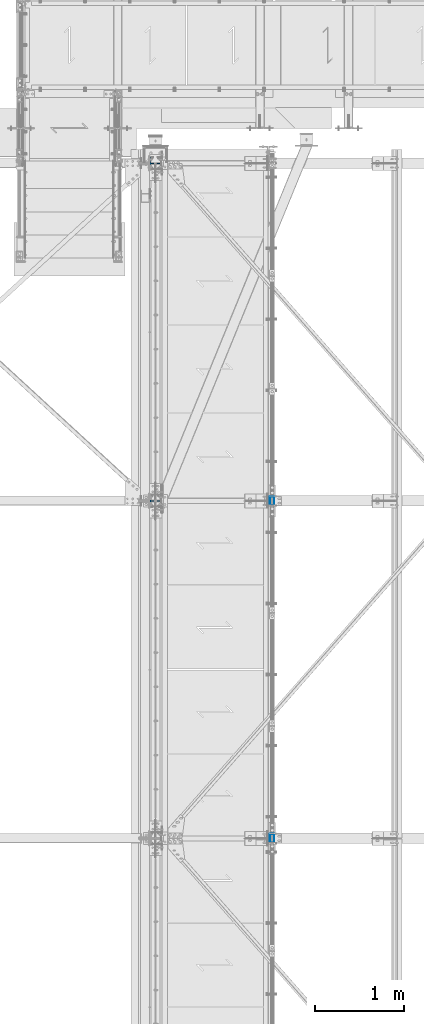
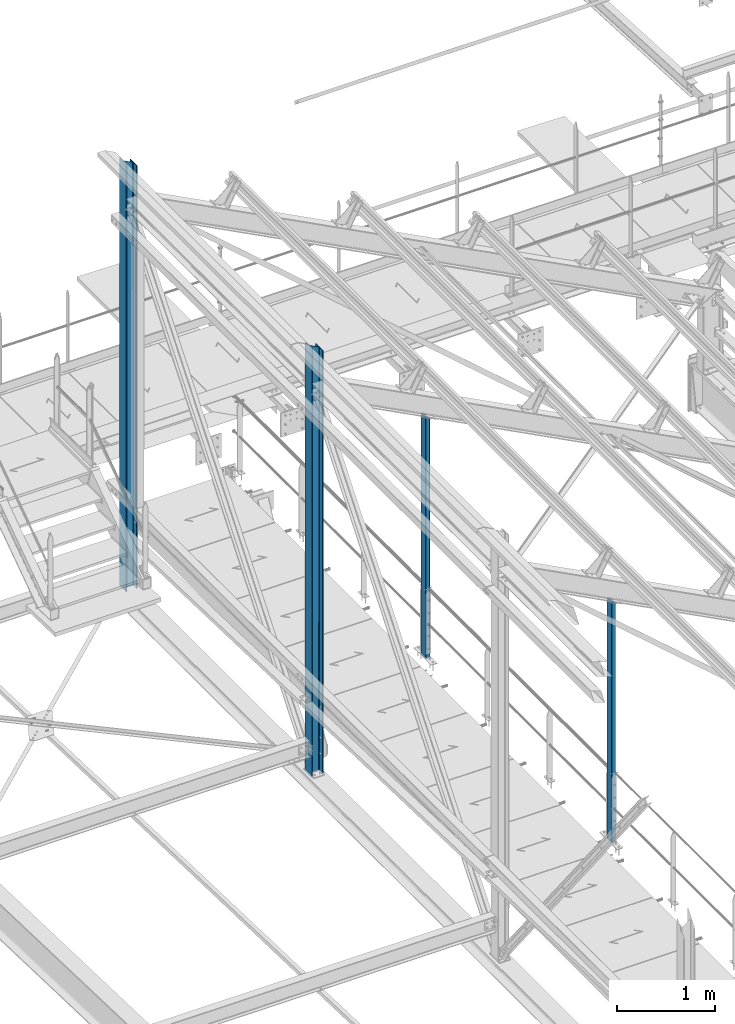
# One storey, part 6 of 496: 4 columns, 4 elements without a shape of their own.
"""IFC2X3 building model written with IfcOpenShell, lengths in millimetres."""

from ifc_helpers import new_model, si_unit, frame, origin_with_axes, origin_2d_with_axis, place, context, subcontext, project, spatial, hollow_rectangle, i_section, extrude, clip, halfspace, material, type_object, element, aggregate, save


model = new_model("IFC2X3")

# Units and contexts
model_context = context("Model", 3, precision=1e-05, world=origin_with_axes())
body_context = subcontext(model_context, "Body", "Model", "MODEL_VIEW")
ifc_project = project(units=[si_unit("LENGTHUNIT", "METRE", prefix="MILLI"), si_unit("AREAUNIT", "SQUARE_METRE"), si_unit("VOLUMEUNIT", "CUBIC_METRE"), si_unit("MASSUNIT", "GRAM", prefix="KILO"), si_unit("TIMEUNIT", "SECOND"), si_unit("PLANEANGLEUNIT", "RADIAN"), si_unit("SOLIDANGLEUNIT", "STERADIAN"), si_unit("THERMODYNAMICTEMPERATUREUNIT", "DEGREE_CELSIUS"), si_unit("LUMINOUSINTENSITYUNIT", "LUMEN")], contexts=[model_context])

# Site, building, storey
site_placement = place(None, origin_with_axes())
site = spatial("IfcSite", under=ifc_project, at=site_placement, CompositionType="ELEMENT")
building_placement = place(site_placement, origin_with_axes())
building = spatial("IfcBuilding", under=site, at=building_placement, Name="Undefined", CompositionType="ELEMENT")
storey_placement = place(building_placement, origin_with_axes())
storey = spatial("IfcBuildingStorey", under=building, at=storey_placement, Name="Undefined", CompositionType="ELEMENT", Elevation=0.0)

# Assembly, column
assembly_1_placement = place(storey_placement, origin_with_axes())
assembly_1 = element("IfcElementAssembly", 1, at=assembly_1_placement, inside=storey, Name="MONTANT", AssemblyPlace="NOTDEFINED", PredefinedType="NOTDEFINED")
ifc_material_1 = material(Name="Undefined/S275-E28")
column_type_1 = type_object("IfcColumnType", Name="HEA140", PredefinedType="NOTDEFINED")
column_1_placement = place(assembly_1_placement, frame((12680.0, 15200.0, 7260.0), z_axis=(0.0, 0.0, 1.0), x_axis=(-1.0, 0.0, 0.0)))
column_1 = element("IfcColumn", 2, at=column_1_placement, type_object=column_type_1, material=ifc_material_1, Name="MONTANT", ObjectType="HEA140", context=body_context, shape_type="Clipping", body=[
    clip(extrude(i_section(OverallWidth=140.0, OverallDepth=133.0, WebThickness=5.5, FlangeThickness=8.5, FilletRadius=12.0, at=origin_2d_with_axis()), frame((0.0, 0.0, 5353.83208547676), z_axis=(0.0, 0.0, -1.0), x_axis=(0.0, 1.0, 0.0)), (0.0, 0.0, 1.0), 5353.83), halfspace(frame((-66.5, 70.0, 5272.97130380653), z_axis=(-0.463528461042155, -7.08866187195592e-09, 0.886082031080583), x_axis=(0.886082031080583, 0.0, 0.463528461042155)), False)),
])
aggregate(assembly_1, [column_1])

assembly_2_placement = place(storey_placement, origin_with_axes())
assembly_2 = element("IfcElementAssembly", 3, at=assembly_2_placement, inside=storey, Name="MONTANT", AssemblyPlace="NOTDEFINED", PredefinedType="NOTDEFINED")
column_2_placement = place(assembly_2_placement, frame((12680.0, 11400.0, 7260.0), z_axis=(0.0, 0.0, 1.0), x_axis=(-1.0, 0.0, 0.0)))
column_2 = element("IfcColumn", 4, at=column_2_placement, type_object=column_type_1, material=ifc_material_1, Name="MONTANT", ObjectType="HEA140", context=body_context, shape_type="Clipping", body=[
    clip(extrude(i_section(OverallWidth=140.0, OverallDepth=133.0, WebThickness=5.5, FlangeThickness=8.5, FilletRadius=12.0, at=origin_2d_with_axis()), frame((0.0, 0.0, 5353.83208547676), z_axis=(0.0, 0.0, -1.0), x_axis=(0.0, 1.0, 0.0)), (0.0, 0.0, 1.0), 5353.83), halfspace(frame((-66.5, 70.0, 5272.97130380653), z_axis=(-0.463528461042155, -7.08866187195592e-09, 0.886082031080583), x_axis=(0.886082031080583, 0.0, 0.463528461042155)), False)),
])
aggregate(assembly_2, [column_2])

assembly_3_placement = place(storey_placement, origin_with_axes())
assembly_3 = element("IfcElementAssembly", 5, at=assembly_3_placement, inside=storey, AssemblyPlace="NOTDEFINED", PredefinedType="NOTDEFINED")
ifc_material_2 = material(Name="Undefined/S235-E24")
column_type_2 = type_object("IfcColumnType", PredefinedType="NOTDEFINED")
column_3_placement = place(assembly_3_placement, frame((13993.9998855295, 11400.0, 8250.0), z_axis=(0.0, 0.0, 1.0), x_axis=(0.0, -1.0, 0.0)))
column_3 = element("IfcColumn", 6, at=column_3_placement, type_object=column_type_2, material=ifc_material_2, context=body_context, shape_type="Clipping", body=[
    clip(extrude(hollow_rectangle(XDim=50.0, YDim=100.0, WallThickness=3.0, InnerFilletRadius=3.0, OuterFilletRadius=6.0, at=origin_2d_with_axis()), frame((0.0, 0.0, 3000.30494892177), z_axis=(0.0, 0.0, -1.0), x_axis=(0.0, 1.0, 0.0)), (0.0, 0.0, 1.0), 3000.3), halfspace(frame((0.0, -63.5993262260417, 3020.36630164538), z_axis=(0.0, -0.46352846104216, -0.886082031080581), x_axis=(1.0, 0.0, 0.0)), True)),
])
aggregate(assembly_3, [column_3])

assembly_4_placement = place(storey_placement, origin_with_axes())
assembly_4 = element("IfcElementAssembly", 7, at=assembly_4_placement, inside=storey, AssemblyPlace="NOTDEFINED", PredefinedType="NOTDEFINED")
column_4_placement = place(assembly_4_placement, frame((13993.9998855295, 7600.0, 8250.0), z_axis=(0.0, 0.0, 1.0), x_axis=(0.0, -1.0, 0.0)))
column_4 = element("IfcColumn", 8, at=column_4_placement, type_object=column_type_2, material=ifc_material_2, context=body_context, shape_type="Clipping", body=[
    clip(extrude(hollow_rectangle(XDim=50.0, YDim=100.0, WallThickness=3.0, InnerFilletRadius=3.0, OuterFilletRadius=6.0, at=origin_2d_with_axis()), frame((0.0, 0.0, 3000.30494892177), z_axis=(0.0, 0.0, -1.0), x_axis=(0.0, 1.0, 0.0)), (0.0, 0.0, 1.0), 3000.3), halfspace(frame((0.0, -63.5993262260417, 3020.36630164538), z_axis=(0.0, -0.46352846104216, -0.886082031080581), x_axis=(1.0, 0.0, 0.0)), True)),
])
aggregate(assembly_4, [column_4])

save(model, "model.ifc")
